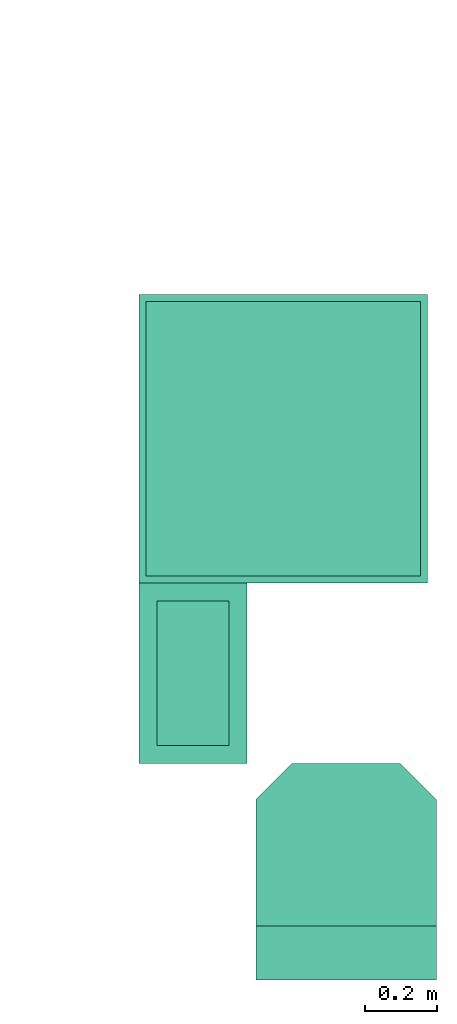
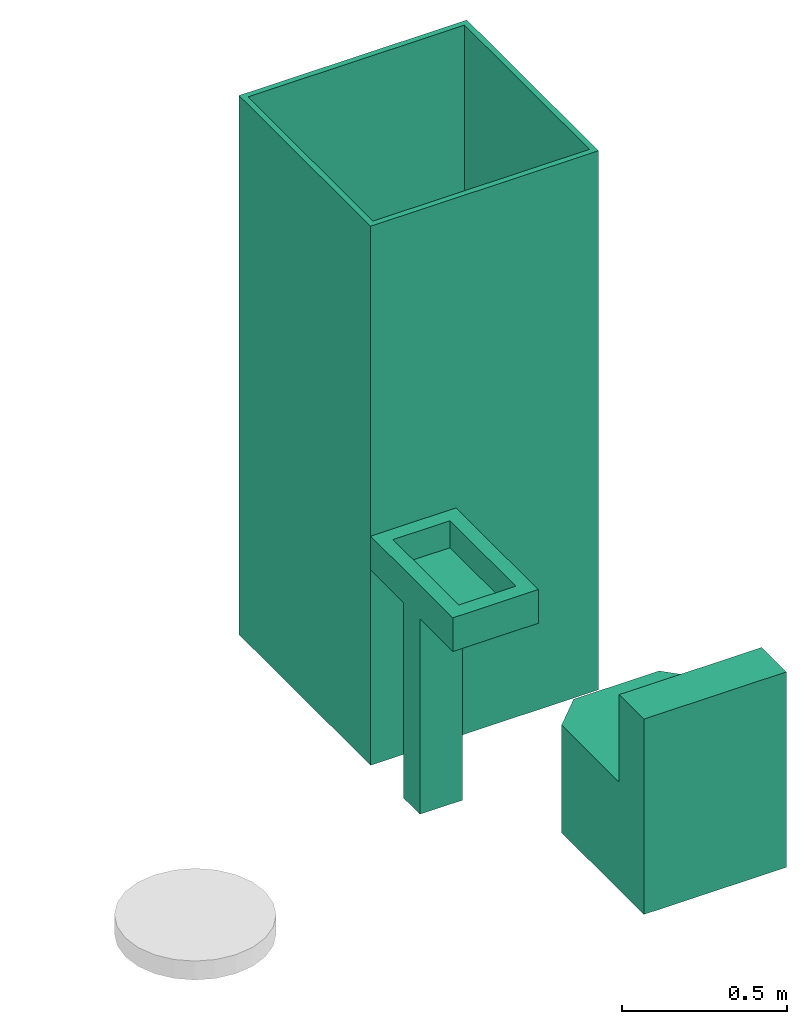
# Not in any storey, part 1 of 2: 3 sanitary terminals.
"""IFC4 model written with IfcOpenShell, lengths in millimetres."""

from ifc_helpers import new_model, entity, si_unit, converted_unit, frame, frame_2d, origin_with_axes, place, context, subcontext, project, polygons, source, transform, mapped, type_object, type_shapes, element, save


model = new_model("IFC4")

# Units and contexts
model_context = context("Model", 3, precision=1e-05, world=origin_with_axes())
plan_context = context("Plan", 2, precision=1e-05, world=frame_2d((0.0, 0.0, 0.0), x_axis=(1.0, 0.0, 0.0)))
body_context = subcontext(model_context, "Body", "Model", "MODEL_VIEW")
ifc_project = project(units=[si_unit("VOLUMEUNIT", "CUBIC_METRE", prefix="MILLI"), si_unit("LENGTHUNIT", "METRE", prefix="MILLI"), converted_unit("PLANEANGLEUNIT", "degree", entity("IfcReal", 0.0174532925199433), si_unit("PLANEANGLEUNIT", "RADIAN"), dimensions=[0, 0, 0, 0, 0, 0, 0]), si_unit("AREAUNIT", "SQUARE_METRE", prefix="MILLI")], contexts=[model_context, plan_context])

# Sanitary terminals
sanitary_terminal_type_1 = type_object("IfcSanitaryTerminalType", Name="SHR", PredefinedType="SHOWER")
shared_shape_1 = source(origin_with_axes(), body_context, "Body", "Tessellation", [
    polygons([(-19.999979019165, -19.9999904632568, 1999.99975585938), (1.4901160284353e-05, 6.55670828564325e-06, 0.0), (-19.999979019165, -779.999938964844, 1999.99975585938), (1.4901160284353e-05, -799.999877929688, 0.0), (-779.999938964844, -19.9999980926514, 1999.99975585938), (-799.999877929688, 0.0, 0.0), (-779.999938964844, -779.999938964844, 1999.99975585938), (-799.999877929688, -799.999877929688, 0.0), (1.4901160284353e-05, -799.999877929688, 1999.99975585938), (-799.999877929688, -799.999877929688, 1999.99975585938), (1.4901160284353e-05, 6.55670828564325e-06, 1999.99975585938), (-799.999877929688, 0.0, 1999.99975585938), (-19.999979019165, -779.999938964844, 49.9999961853027), (-779.999938964844, -779.999938964844, 49.9999961853027), (-19.999979019165, -19.9999904632568, 49.9999961853027), (-779.999938964844, -19.9999980926514, 49.9999961853027)], [[[5, 7, 14, 16]], [[4, 9, 10, 8]], [[8, 10, 12, 6]], [[6, 2, 4, 8]], [[2, 11, 9, 4]], [[6, 12, 11, 2]], [[3, 7, 10, 9]], [[1, 3, 9, 11]], [[7, 5, 12, 10]], [[5, 1, 11, 12]], [[15, 16, 14, 13]], [[7, 3, 13, 14]], [[1, 5, 16, 15]], [[3, 1, 15, 13]]]),
])
type_shapes(sanitary_terminal_type_1, [shared_shape_1])
sanitary_terminal_1_placement = place(None, frame((199.999570846558, 2099.99942779541, 0.0), z_axis=(0.0, 0.0, 1.0), x_axis=(-4.37113882867379e-08, 1.0, 0.0)))
element("IfcSanitaryTerminal", 1, at=sanitary_terminal_1_placement, type_object=sanitary_terminal_type_1, Name="SanitaryTerminal", PredefinedType="NOTDEFINED", context=body_context, shape_type="MappedRepresentation", body=[
    mapped(shared_shape_1, transform((0.0, 0.0, 0.0), x_axis=(1.0, 0.0, 0.0), y_axis=(0.0, 1.0, 0.0), z_axis=(0.0, 0.0, 1.0), scale=1.0)),
])
sanitary_terminal_type_2 = type_object("IfcSanitaryTerminalType", Name="WC - Toilet - 600x500", PredefinedType="WCSEAT")
shared_shape_2 = source(origin_with_axes(), body_context, "Body", "Tessellation", [
    polygons([(150.0, 6.55670828564325e-06, 399.999847412109), (150.0, 6.55670828564325e-06, 0.0), (150.0, -499.999908447266, 399.999847412109), (150.0, -499.999908447266, 0.0), (-5.96046411374118e-05, 6.55670828564325e-06, 0.0), (-5.96046411374118e-05, -499.999908447266, 0.0), (-5.96046411374118e-05, -499.999908447266, 399.999847412109), (-5.96046411374118e-05, 6.55670828564325e-06, 399.999847412109), (150.0, -499.999908447266, 724.999877929688), (150.0, 6.55670828564325e-06, 724.999877929688), (-5.96046411374118e-05, -499.999908447266, 724.999877929688), (-5.96046411374118e-05, 6.55670828564325e-06, 724.999877929688), (599.999938964844, -99.9999923706055, 399.999847412109), (499.999938964844, -1.39081669203733e-06, 399.999847412109), (499.999938964844, -1.39081669203733e-06, 0.0), (599.999938964844, -100.0, 0.0), (499.999938964844, -499.999908447266, 399.999847412109), (599.999938964844, -399.999908447266, 399.999847412109), (599.999938964844, -399.999908447266, 0.0), (499.999938964844, -499.999908447266, 0.0)], [[[13, 14, 1, 3, 17, 18]], [[2, 4, 6, 5]], [[2, 15, 16, 19, 20, 4]], [[20, 17, 3, 4]], [[6, 7, 8, 5]], [[3, 1, 10, 9]], [[1, 2, 5, 8]], [[4, 3, 7, 6]], [[9, 10, 12, 11]], [[1, 8, 12, 10]], [[7, 3, 9, 11]], [[8, 7, 11, 12]], [[13, 16, 15, 14]], [[2, 1, 14, 15]], [[17, 20, 19, 18]], [[16, 13, 18, 19]]]),
])
type_shapes(sanitary_terminal_type_2, [shared_shape_2])
sanitary_terminal_2_placement = place(None, frame((524.024486541748, 199.999570846558, 0.0), z_axis=(0.0, 0.0, 1.0), x_axis=(-4.37113882867379e-08, 1.0, 0.0)))
element("IfcSanitaryTerminal", 2, at=sanitary_terminal_2_placement, type_object=sanitary_terminal_type_2, Name="SanitaryTerminal", PredefinedType="NOTDEFINED", context=body_context, shape_type="MappedRepresentation", body=[
    mapped(shared_shape_2, transform((0.0, 0.0, 0.0), x_axis=(1.0, 0.0, 0.0), y_axis=(0.0, 1.0, 0.0), z_axis=(0.0, 0.0, 1.0), scale=1.0)),
])
sanitary_terminal_type_3 = type_object("IfcSanitaryTerminalType", Name="WHB_500x300", PredefinedType="WASHHANDBASIN")
shared_shape_3 = source(origin_with_axes(), body_context, "Body", "Tessellation", [
    polygons([(-49.9999656677246, -50.0000076293945, 849.999877929688), (-49.9999656677246, -449.999938964844, 849.999877929688), (-249.999908447266, -49.9999961853027, 849.999877929688), (-249.999908447266, -449.999938964844, 849.999877929688), (-149.999984741211, -200.000030517578, 3.85374079314715e-07), (2.98023205687059e-05, -499.999938964844, 849.999877929688), (-299.999908447266, -499.999908447266, 849.999877929688), (2.98023205687059e-05, -1.5298986909329e-05, 849.999877929688), (-299.999908447266, 0.0, 849.999877929688), (-49.9999656677246, -449.999938964844, 749.999816894531), (-249.999908447266, -449.999938964844, 749.999816894531), (-49.9999656677246, -50.0000076293945, 749.999816894531), (-249.999908447266, -49.9999961853027, 749.999816894531), (2.98023205687059e-05, -1.5298986909329e-05, 724.999877929688), (-299.999908447266, -499.999908447266, 724.999877929688), (2.98023205687059e-05, -499.999938964844, 724.999877929688), (-299.999908447266, 0.0, 724.999877929688), (-49.9999694824219, -1.5298986909329e-05, 724.999877929688), (-299.999877929688, -299.999908447266, 0.0), (-49.9999694824219, -499.999938964844, 724.999877929688), (-149.999938964844, -300.0, 3.85374079314715e-07), (-49.9999809265137, -200.0, 724.999877929688), (-299.999908447266, -199.999984741211, 724.999877929688), (-299.999877929688, -274.999908447266, 724.999877929688), (-299.999908447266, -225.0, 724.999877929688), (-299.999877929688, -299.999908447266, 724.999877929688), (-49.9999504089355, -299.999969482422, 724.999877929688), (-299.999908447266, -199.999984741211, 0.0), (-149.999984741211, -200.000030517578, 724.999877929688), (-149.999938964844, -300.0, 724.999877929688), (-149.999984741211, -225.000045776367, 724.999877929688), (-149.999938964844, -275.0, 724.999877929688)], [[[3, 4, 11, 13]], [[16, 6, 7, 15, 20]], [[15, 7, 9, 17, 23, 25, 24, 26]], [[21, 19, 28, 5]], [[14, 8, 6, 16]], [[17, 9, 8, 14, 18]], [[2, 4, 7, 6]], [[1, 2, 6, 8]], [[4, 3, 9, 7]], [[3, 1, 8, 9]], [[12, 13, 11, 10]], [[4, 2, 10, 11]], [[1, 3, 13, 12]], [[2, 1, 12, 10]], [[14, 16, 20, 27, 32, 31, 22, 18]], [[27, 30, 32]], [[24, 25, 23, 28, 19, 26]], [[31, 32, 30, 21, 5, 29]], [[20, 15, 26, 30, 27]], [[17, 18, 22, 29, 23]], [[22, 31, 29]], [[30, 26, 19, 21]], [[28, 23, 29, 5]]]),
])
type_shapes(sanitary_terminal_type_3, [shared_shape_3])
sanitary_terminal_3_placement = place(None, frame((499.999403953552, 1300.25517940521, 0.0), z_axis=(0.0, 0.0, 1.0), x_axis=(1.0, 0.0, 0.0)))
element("IfcSanitaryTerminal", 3, at=sanitary_terminal_3_placement, type_object=sanitary_terminal_type_3, Name="SanitaryTerminal", PredefinedType="NOTDEFINED", context=body_context, shape_type="MappedRepresentation", body=[
    mapped(shared_shape_3, transform((0.0, 0.0, 0.0), x_axis=(1.0, 0.0, 0.0), y_axis=(0.0, 1.0, 0.0), z_axis=(0.0, 0.0, 1.0), scale=1.0)),
])

save(model, "model.ifc")
